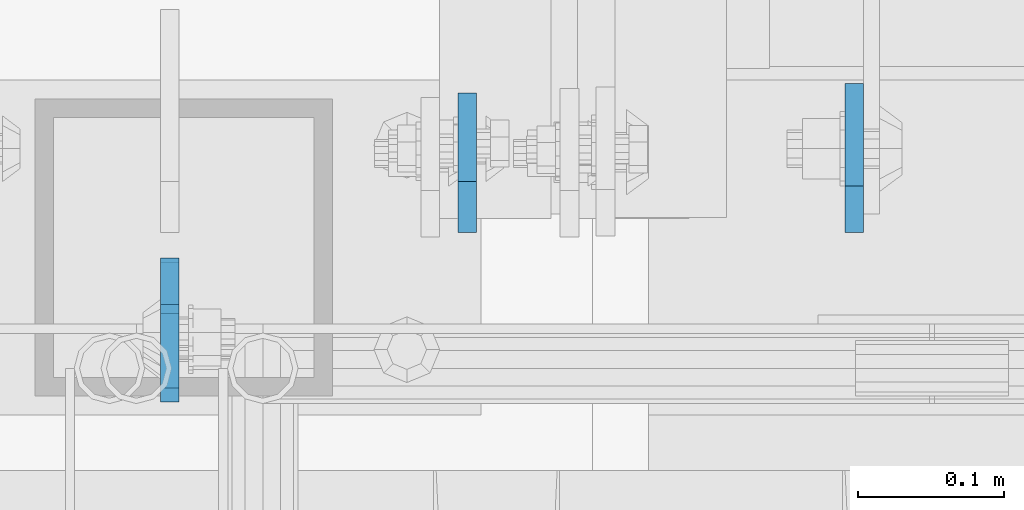
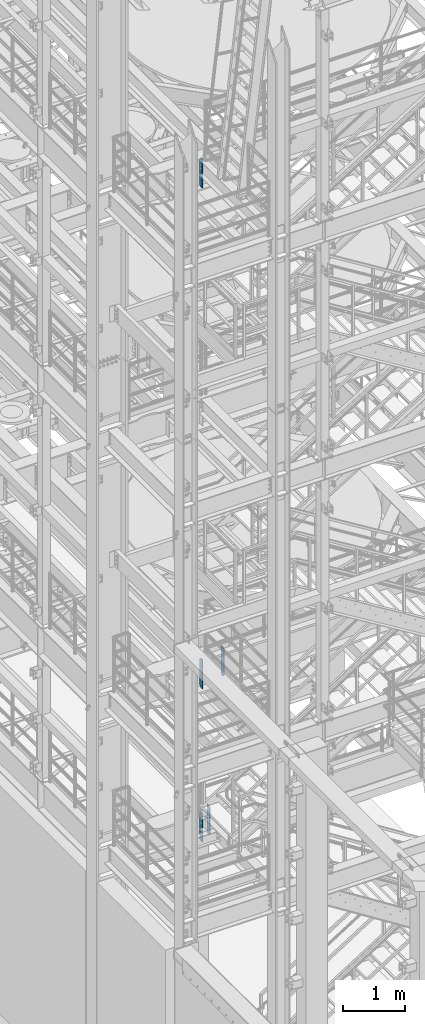
# One storey, part 1472 of 1876: 5 plates, 3 elements without a shape of their own.
"""IFC2X3 building model written with IfcOpenShell, lengths in millimetres."""

from ifc_helpers import new_model, si_unit, frame, origin_with_axes, place, context, subcontext, project, spatial, faceted_brep, material, type_object, element, aggregate, save


model = new_model("IFC2X3")

# Units and contexts
model_context = context("Model", 3, precision=1e-05, world=origin_with_axes())
body_context = subcontext(model_context, "Body", "Model", "MODEL_VIEW")
ifc_project = project(units=[si_unit("LENGTHUNIT", "METRE", prefix="MILLI"), si_unit("AREAUNIT", "SQUARE_METRE"), si_unit("VOLUMEUNIT", "CUBIC_METRE"), si_unit("MASSUNIT", "GRAM", prefix="KILO"), si_unit("TIMEUNIT", "SECOND"), si_unit("PLANEANGLEUNIT", "RADIAN"), si_unit("SOLIDANGLEUNIT", "STERADIAN"), si_unit("THERMODYNAMICTEMPERATUREUNIT", "DEGREE_CELSIUS"), si_unit("LUMINOUSINTENSITYUNIT", "LUMEN")], contexts=[model_context])

# Site, building, storey
site_placement = place(None, origin_with_axes())
site = spatial("IfcSite", under=ifc_project, at=site_placement, CompositionType="ELEMENT")
building_placement = place(site_placement, origin_with_axes())
building = spatial("IfcBuilding", under=site, at=building_placement, Name="Undefined", CompositionType="ELEMENT")
storey_placement = place(building_placement, origin_with_axes())
storey = spatial("IfcBuildingStorey", under=building, at=storey_placement, Name="Undefined", CompositionType="ELEMENT", Elevation=0.0)

# Assembly, plate
assembly_1_placement = place(storey_placement, origin_with_axes())
assembly_1 = element("IfcElementAssembly", 1, at=assembly_1_placement, inside=storey, Name="BEAM", AssemblyPlace="NOTDEFINED", PredefinedType="RIGID_FRAME")
ifc_material = material(Name="STEEL/A36")
plate_type_1 = type_object("IfcPlateType", PredefinedType="NOTDEFINED")
plate_1_placement = place(assembly_1_placement, frame((1717.67499990463, -4579.14375, 17386.3), z_axis=(0.0, 0.0, 1.0), x_axis=(0.0, -1.0, 0.0)))
plate_1 = element("IfcPlate", 2, at=plate_1_placement, type_object=plate_type_1, material=ifc_material, Name="PLATE", context=body_context, shape_type="Brep", body=[
    faceted_brep([(0.0, -6.34999999999991, 31.75), (0.0, -6.34999999999991, 539.75), (0.0, 6.34999999999991, 539.75), (0.0, 6.34999999999991, 31.75), (31.75, -6.34999999999991, 571.5), (31.75, 6.34999999999991, 571.5), (88.9000015258789, -6.34999999999991, 571.5), (88.9000015258789, 6.34999999999991, 571.5), (88.9000015258789, -6.34999999999991, 0.0), (88.9000015258789, 6.34999999999991, 0.0), (31.75, -6.34999999999991, 0.0), (31.75, 6.34999999999991, 0.0)], [[[0, 1, 2, 3]], [[1, 4, 5, 2]], [[4, 6, 7, 5]], [[6, 8, 9, 7]], [[8, 10, 11, 9]], [[10, 0, 3, 11]], [[5, 7, 9, 11, 3, 2]], [[10, 8, 6, 4, 1, 0]]]),
])
aggregate(assembly_1, [plate_1])

assembly_2_placement = place(storey_placement, origin_with_axes())
assembly_2 = element("IfcElementAssembly", 3, at=assembly_2_placement, inside=storey, Name="BEAM", AssemblyPlace="NOTDEFINED", PredefinedType="RIGID_FRAME")
plate_type_2 = type_object("IfcPlateType", PredefinedType="NOTDEFINED")
plate_2_placement = place(assembly_2_placement, frame((1717.67499990463, -4582.31875, 7543.8), z_axis=(0.0, 0.0, 1.0), x_axis=(0.0, -1.0, 0.0)))
plate_2 = element("IfcPlate", 4, at=plate_2_placement, type_object=plate_type_2, material=ifc_material, Name="PLATE", context=body_context, shape_type="Brep", body=[
    faceted_brep([(0.0, -6.34999999999991, 34.9249992370605), (0.0, -6.35000000000036, 538.162475585938), (0.0, 6.35000000000036, 538.162475585938), (0.0, 6.34999999999991, 34.9249992370605), (34.9249992370605, -6.34999999999991, 573.087524414062), (34.9249992370605, 6.34999999999991, 573.087524414062), (95.25, -6.34999999999991, 573.087524414062), (95.25, 6.34999999999991, 573.087524414062), (95.25, -6.35000000000036, 0.0), (95.25, 6.35000000000036, 0.0), (34.9249992370605, -6.34999999999991, 0.0), (34.9249992370605, 6.34999999999991, 0.0)], [[[0, 1, 2, 3]], [[1, 4, 5, 2]], [[4, 6, 7, 5]], [[6, 8, 9, 7]], [[8, 10, 11, 9]], [[10, 0, 3, 11]], [[5, 7, 9, 11, 3, 2]], [[10, 8, 6, 4, 1, 0]]]),
])

# Assembly, plates
assembly_3_placement = place(storey_placement, origin_with_axes())
assembly_3 = element("IfcElementAssembly", 5, at=assembly_3_placement, inside=storey, Name="BEAM", AssemblyPlace="NOTDEFINED", PredefinedType="RIGID_FRAME")
plate_3_placement = place(assembly_3_placement, frame((1717.675, -4582.31875, 4521.2), z_axis=(0.0, 0.0, 1.0), x_axis=(0.0, -1.0, 0.0)))
plate_3 = element("IfcPlate", 6, at=plate_3_placement, type_object=plate_type_2, material=ifc_material, Name="PLATE", context=body_context, shape_type="Brep", body=[
    faceted_brep([(0.0, -6.34999999999991, 34.9249992370605), (0.0, -6.35000000000036, 538.162475585938), (0.0, 6.35000000000036, 538.162475585938), (0.0, 6.34999999999991, 34.9249992370605), (34.9249992370605, -6.34999999999991, 573.087524414062), (34.9249992370605, 6.34999999999991, 573.087524414062), (95.25, -6.34999999999991, 573.087524414062), (95.25, 6.34999999999991, 573.087524414062), (95.25, -6.35000000000036, 0.0), (95.25, 6.35000000000036, 0.0), (34.9249992370605, -6.34999999999991, 0.0), (34.9249992370605, 6.34999999999991, 0.0)], [[[0, 1, 2, 3]], [[1, 4, 5, 2]], [[4, 6, 7, 5]], [[6, 8, 9, 7]], [[8, 10, 11, 9]], [[10, 0, 3, 11]], [[5, 7, 9, 11, 3, 2]], [[10, 8, 6, 4, 1, 0]]]),
])
plate_4_placement = place(assembly_3_placement, frame((1920.875, -4561.68125, 4521.2), z_axis=(0.0, 0.0, 1.0), x_axis=(0.0, 1.0, 0.0)))
plate_4 = element("IfcPlate", 7, at=plate_4_placement, type_object=plate_type_2, material=ifc_material, Name="PLATE", context=body_context, shape_type="Brep", body=[
    faceted_brep([(0.0, -6.34999999999991, 34.9249992370605), (0.0, -6.35000000000036, 538.162475585938), (0.0, 6.35000000000036, 538.162475585938), (0.0, 6.34999999999991, 34.9249992370605), (34.9249992370605, -6.34999999999991, 573.087524414062), (34.9249992370605, 6.34999999999991, 573.087524414062), (95.25, -6.34999999999991, 573.087524414062), (95.25, 6.34999999999991, 573.087524414062), (95.25, -6.35000000000036, 0.0), (95.25, 6.35000000000036, 0.0), (34.9249992370605, -6.34999999999991, 0.0), (34.9249992370605, 6.34999999999991, 0.0)], [[[0, 1, 2, 3]], [[1, 4, 5, 2]], [[4, 6, 7, 5]], [[6, 8, 9, 7]], [[8, 10, 11, 9]], [[10, 0, 3, 11]], [[5, 7, 9, 11, 3, 2]], [[10, 8, 6, 4, 1, 0]]]),
])
aggregate(assembly_3, [plate_3, plate_4])

# Plate
plate_type_3 = type_object("IfcPlateType", PredefinedType="NOTDEFINED")
plate_5_placement = place(assembly_2_placement, frame((2185.19374990463, -4561.68125, 7543.8), z_axis=(0.0, 0.0, 1.0), x_axis=(0.0, 1.0, 0.0)))
plate_5 = element("IfcPlate", 8, at=plate_5_placement, type_object=plate_type_3, material=ifc_material, Name="PLATE", context=body_context, shape_type="Brep", body=[
    faceted_brep([(0.0, -6.34999999999991, 31.75), (0.0, -6.35000000000036, 541.337524414062), (0.0, 6.35000000000036, 541.337524414062), (0.0, 6.34999999999991, 31.75), (31.75, -6.35000000000036, 573.087524414062), (31.75, 6.35000000000036, 573.087524414062), (101.599998474121, -6.35000000000036, 573.087524414062), (101.599998474121, 6.35000000000036, 573.087524414062), (101.599998474121, -6.35000000000036, 0.0), (101.599998474121, 6.35000000000036, 0.0), (31.75, -6.34999999999991, 0.0), (31.75, 6.34999999999991, 0.0)], [[[0, 1, 2, 3]], [[1, 4, 5, 2]], [[4, 6, 7, 5]], [[6, 8, 9, 7]], [[8, 10, 11, 9]], [[10, 0, 3, 11]], [[5, 7, 9, 11, 3, 2]], [[10, 8, 6, 4, 1, 0]]]),
])

aggregate(assembly_2, [plate_2, plate_5])

save(model, "model.ifc")
